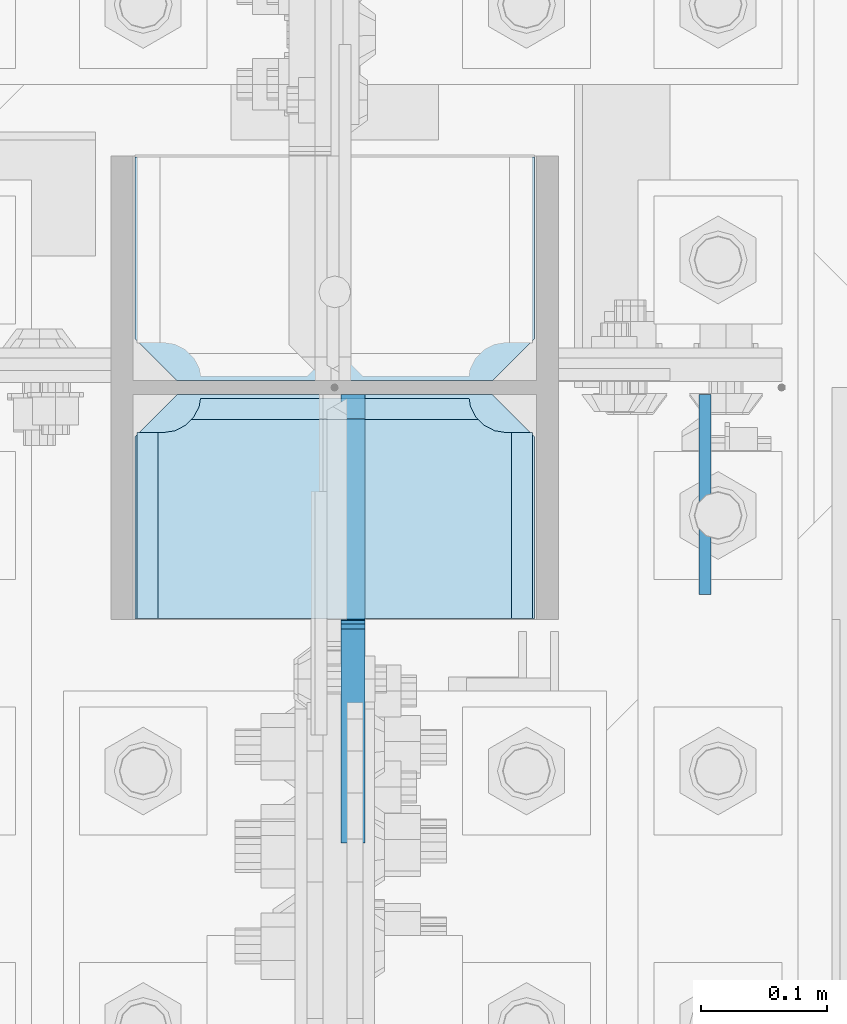
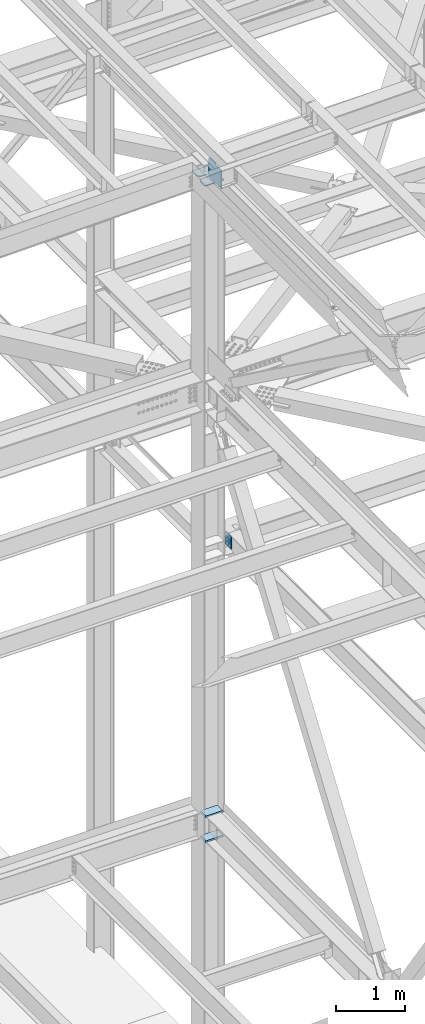
# One storey, part 3200 of 3843: 6 plates, 2 elements without a shape of their own.
"""IFC2X3 building model written with IfcOpenShell, lengths in millimetres."""

from ifc_helpers import new_model, si_unit, frame, origin_with_axes, place, context, subcontext, project, spatial, faceted_brep, material, type_object, element, aggregate, save


model = new_model("IFC2X3")

# Units and contexts
model_context = context("Model", 3, precision=1e-05, world=origin_with_axes())
body_context = subcontext(model_context, "Body", "Model", "MODEL_VIEW")
ifc_project = project(units=[si_unit("LENGTHUNIT", "METRE", prefix="MILLI"), si_unit("AREAUNIT", "SQUARE_METRE"), si_unit("VOLUMEUNIT", "CUBIC_METRE"), si_unit("MASSUNIT", "GRAM", prefix="KILO"), si_unit("TIMEUNIT", "SECOND"), si_unit("PLANEANGLEUNIT", "RADIAN"), si_unit("SOLIDANGLEUNIT", "STERADIAN"), si_unit("THERMODYNAMICTEMPERATUREUNIT", "DEGREE_CELSIUS"), si_unit("LUMINOUSINTENSITYUNIT", "LUMEN")], contexts=[model_context])

# Site, building, storey
site_placement = place(None, origin_with_axes())
site = spatial("IfcSite", under=ifc_project, at=site_placement, CompositionType="ELEMENT")
building_placement = place(site_placement, origin_with_axes())
building = spatial("IfcBuilding", under=site, at=building_placement, Name="Undefined", CompositionType="ELEMENT")
storey_placement = place(building_placement, origin_with_axes())
storey = spatial("IfcBuildingStorey", under=building, at=storey_placement, Name="Undefined", CompositionType="ELEMENT", Elevation=0.0)

# Assembly, plates
assembly_1_placement = place(storey_placement, origin_with_axes())
assembly_1 = element("IfcElementAssembly", 1, at=assembly_1_placement, inside=storey, Name="COLUMN", AssemblyPlace="NOTDEFINED", PredefinedType="RIGID_FRAME")
ifc_material = material(Name="STEEL/A572-50")
plate_type_1 = type_object("IfcPlateType", PredefinedType="NOTDEFINED")
plate_1_placement = place(assembly_1_placement, frame((77171.55, 25799.25625, 45946.8205507398), z_axis=(-1.0, 0.0, 0.0), x_axis=(0.0, -1.0, 0.0)))
plate_1 = element("IfcPlate", 2, at=plate_1_placement, type_object=plate_type_1, material=ifc_material, Name="PLATE", context=body_context, shape_type="Brep", body=[
    faceted_brep([(0.0, -6.3499999046162, 0.0), (0.0, -6.34999999999854, 317.5), (0.0, 6.34999999999854, 317.5), (7.27595761418343e-12, 6.3499999046162, 0.0), (144.462501525879, -6.34999999999854, 317.5), (144.462501525879, 6.34999999999854, 317.5), (177.800003051758, -6.34999999999854, 284.162498474121), (177.800003051758, 6.34999999999854, 284.162498474121), (177.800003051758, -6.34999999999854, 33.3375015258789), (177.800003051758, 6.34999999999854, 33.3375015258789), (144.462501525879, -6.34999999999854, 0.0), (144.462501525879, 6.34999999999854, 0.0)], [[[0, 1, 2, 3]], [[1, 4, 5, 2]], [[4, 6, 7, 5]], [[6, 8, 9, 7]], [[8, 10, 11, 9]], [[10, 0, 3, 11]], [[5, 7, 9, 11, 3, 2]], [[10, 8, 6, 4, 1, 0]]]),
])
plate_type_2 = type_object("IfcPlateType", PredefinedType="NOTDEFINED")
plate_2_placement = place(assembly_1_placement, frame((76854.05, 25432.54375, 45902.4145640179), z_axis=(1.0, 0.0, 0.0), x_axis=(0.0, 1.0, 0.0)))
plate_2 = element("IfcPlate", 3, at=plate_2_placement, type_object=plate_type_2, material=ifc_material, Name="PLATE", context=body_context, shape_type="Brep", body=[
    faceted_brep([(0.0, -9.52500000000146, 0.0), (0.0, -9.52500000000146, 317.5), (0.0, 9.52500000000146, 317.5), (0.0, 9.52500000000146, 0.0), (144.462501525879, -9.52500000000146, 317.5), (144.462501525879, 9.52500000000146, 317.5), (177.800003051758, -9.52500000000146, 284.162498474121), (177.800003051758, 9.52500000000146, 284.162498474121), (177.800003051758, -9.52500000000146, 33.3375015258789), (177.800003051758, 9.52500000000146, 33.3375015258789), (144.462501525879, -9.52500000000146, 0.0), (144.462501525879, 9.52500000000146, 0.0)], [[[0, 1, 2, 3]], [[1, 4, 5, 2]], [[4, 6, 7, 5]], [[6, 8, 9, 7]], [[8, 10, 11, 9]], [[10, 0, 3, 11]], [[5, 7, 9, 11, 3, 2]], [[10, 8, 6, 4, 1, 0]]]),
])
plate_type_3 = type_object("IfcPlateType", PredefinedType="NOTDEFINED")
plate_3_placement = place(assembly_1_placement, frame((76852.4625, 25432.54375, 34358.2625), z_axis=(1.0, 0.0, 0.0), x_axis=(0.0, 1.0, 0.0)))
plate_3 = element("IfcPlate", 4, at=plate_3_placement, type_object=plate_type_3, material=ifc_material, Name="PLATE", context=body_context, shape_type="Brep", body=[
    faceted_brep([(160.070927103505, 10.9213260423567, 48.2144734940957), (158.127465664529, 14.2874999999985, 46.2710120551201), (158.127465664529, 14.2874999999985, 274.403987944883), (160.070927103505, 10.9213260423567, 272.460526505907), (168.479274789282, -3.64235936916521, 268.176259371801), (174.625250047106, -14.2874999999985, 267.202832520343), (174.625250047106, -14.2874999999985, 53.4721674796601), (168.479274789282, -3.64235936916521, 52.4987406282016), (147.637499618531, 14.2874999999985, 19.672284334898), (147.637499618531, -14.2874999999985, 3.17449995232164), (0.0, -14.2874999999985, 3.17449995232164), (0.0, 14.2874999999985, 19.672284334898), (0.0, 14.2874999999985, 301.002715665105), (0.0, -14.2874999999985, 317.500500047681), (147.63749961853, -14.2874999999985, 317.500500047681), (147.63749961853, 14.2874999999985, 301.002715665105), (147.63749961853, -14.2874999999985, 296.862501907352), (147.63749961853, 14.2874999999985, 296.862501907352), (149.113757464445, -14.2874999999985, 287.541776696642), (149.113757464445, 14.2874999999985, 287.541776696642), (153.398024598548, -14.2874999999985, 279.133429010864), (153.398024598548, 14.2874999999985, 279.133429010864), (160.070927103505, -14.2874999999985, 272.460526505907), (168.479274789282, -14.2874999999985, 268.176259371801), (168.479274789282, -14.2874999999985, 52.4987406282016), (160.070927103505, -14.2874999999985, 48.2144734940957), (153.398024598548, -14.2874999999985, 41.5415709891386), (153.398024598548, 14.2874999999985, 41.5415709891386), (149.113757464449, -14.2874999999985, 33.1332233033609), (149.113757464449, 14.2874999999985, 33.1332233033609), (147.63749961853, -14.2874999999985, 23.8124980926514), (147.63749961853, 14.2874999999985, 23.8124980926514)], [[[0, 1, 2, 3, 4, 5, 6, 7]], [[8, 9, 10, 11]], [[12, 13, 14, 15]], [[13, 12, 11, 10]], [[16, 17, 15, 14]], [[16, 18, 19, 17]], [[18, 20, 21, 19]], [[21, 20, 22, 3, 2]], [[22, 23, 4, 3]], [[23, 5, 4]], [[24, 7, 6]], [[24, 25, 0, 7]], [[25, 26, 27, 1, 0]], [[26, 28, 29, 27]], [[28, 30, 31, 29]], [[31, 30, 9, 8]], [[27, 29, 31, 8, 11, 12, 15, 17, 19, 21, 2, 1]], [[9, 30, 28, 26, 25, 24, 6, 5, 23, 22, 20, 18, 16, 14, 13, 10]]]),
])
plate_4_placement = place(assembly_1_placement, frame((76852.4625, 25432.54375, 34796.4125), z_axis=(1.0, 0.0, 0.0), x_axis=(0.0, 1.0, 0.0)))
plate_4 = element("IfcPlate", 5, at=plate_4_placement, type_object=plate_type_3, material=ifc_material, Name="PLATE", context=body_context, shape_type="Brep", body=[
    faceted_brep([(160.070927103505, 10.9213260423567, 48.2144734940957), (158.127465664529, 14.2874999999985, 46.2710120551201), (158.127465664529, 14.2874999999985, 274.403987944883), (160.070927103505, 10.9213260423567, 272.460526505907), (168.479274789282, -3.64235936916521, 268.176259371801), (174.625250047106, -14.2874999999985, 267.202832520343), (174.625250047106, -14.2874999999985, 53.4721674796601), (168.479274789282, -3.64235936916521, 52.4987406282016), (147.637499618531, 14.2874999999985, 19.672284334898), (147.637499618531, -14.2874999999985, 3.17449995232164), (0.0, -14.2874999999985, 3.17449995232164), (0.0, 14.2874999999985, 19.672284334898), (0.0, 14.2874999999985, 301.002715665105), (0.0, -14.2874999999985, 317.500500047681), (147.63749961853, -14.2874999999985, 317.500500047681), (147.63749961853, 14.2874999999985, 301.002715665105), (147.63749961853, -14.2874999999985, 296.862501907352), (147.63749961853, 14.2874999999985, 296.862501907352), (149.113757464445, -14.2874999999985, 287.541776696642), (149.113757464445, 14.2874999999985, 287.541776696642), (153.398024598548, -14.2874999999985, 279.133429010864), (153.398024598548, 14.2874999999985, 279.133429010864), (160.070927103505, -14.2874999999985, 272.460526505907), (168.479274789282, -14.2874999999985, 268.176259371801), (168.479274789282, -14.2874999999985, 52.4987406282016), (160.070927103505, -14.2874999999985, 48.2144734940957), (153.398024598548, -14.2874999999985, 41.5415709891386), (153.398024598548, 14.2874999999985, 41.5415709891386), (149.113757464449, -14.2874999999985, 33.1332233033609), (149.113757464449, 14.2874999999985, 33.1332233033609), (147.63749961853, -14.2874999999985, 23.8124980926514), (147.63749961853, 14.2874999999985, 23.8124980926514)], [[[0, 1, 2, 3, 4, 5, 6, 7]], [[8, 9, 10, 11]], [[12, 13, 14, 15]], [[13, 12, 11, 10]], [[16, 17, 15, 14]], [[16, 18, 19, 17]], [[18, 20, 21, 19]], [[21, 20, 22, 3, 2]], [[22, 23, 4, 3]], [[23, 5, 4]], [[24, 7, 6]], [[24, 25, 0, 7]], [[25, 26, 27, 1, 0]], [[26, 28, 29, 27]], [[28, 30, 31, 29]], [[31, 30, 9, 8]], [[27, 29, 31, 8, 11, 12, 15, 17, 19, 21, 2, 1]], [[9, 30, 28, 26, 25, 24, 6, 5, 23, 22, 20, 18, 16, 14, 13, 10]]]),
])

# Assembly, plate
assembly_2_placement = place(storey_placement, origin_with_axes())
assembly_2 = element("IfcElementAssembly", 6, at=assembly_2_placement, inside=storey, Name="BEAM", AssemblyPlace="NOTDEFINED", PredefinedType="RIGID_FRAME")
plate_type_4 = type_object("IfcPlateType", PredefinedType="NOTDEFINED")
plate_5_placement = place(assembly_2_placement, frame((77307.28125, 25610.34375, 39570.025), z_axis=(0.0, -1.0, 0.0), x_axis=(0.0, 0.0, -1.0)))
plate_5 = element("IfcPlate", 7, at=plate_5_placement, type_object=plate_type_4, material=ifc_material, Name="PLATE", context=body_context, shape_type="Brep", body=[
    faceted_brep([(0.0, -4.76249999999709, 0.0), (0.0, -4.76249999999709, 158.749999526888), (0.0, 4.76249999999709, 158.749999526888), (0.0, 4.76249999999709, 0.0), (228.599999999999, -4.76249999999709, 158.749999526888), (228.599999999999, 4.76249999999709, 158.749999526888), (228.600006103079, -4.7625000004482, 7.27595761418343e-12), (228.600006103079, 4.76249999954598, -7.27595761418343e-12)], [[[0, 1, 2, 3]], [[1, 4, 5, 2]], [[4, 6, 7, 5]], [[6, 0, 3, 7]], [[5, 7, 3, 2]], [[6, 4, 1, 0]]]),
])
aggregate(assembly_2, [plate_5])

# Plate
plate_type_5 = type_object("IfcPlateType", PredefinedType="NOTDEFINED")
plate_6_placement = place(assembly_1_placement, frame((77027.0875006341, 25610.34375, 45930.9895639882), z_axis=(0.0, -0.707106781186682, 0.707106781186413), x_axis=(0.0, -0.707106781186548, -0.707106781186548)))
plate_6 = element("IfcPlate", 8, at=plate_6_placement, type_object=plate_type_5, material=ifc_material, Name="PLATE", context=body_context, shape_type="Brep", body=[
    faceted_brep([(0.0, -9.52500000000146, 0.0), (-215.526146904645, -9.52499999999418, 215.526146904607), (-215.526146904645, 9.52499999999418, 215.526146904607), (0.0, 9.52500000000146, 0.0), (-215.526146904645, -9.52499999999418, 242.466915267682), (-215.526146904645, 9.52499999999418, 242.466915267682), (-102.711679384272, -9.52499999999418, 355.28138278808), (-102.711679384272, 9.52499999999418, 355.28138278808), (-93.731422658424, -9.52499999999418, 346.301126065489), (-93.731422658424, 9.52499999999418, 346.301126065489), (-89.6112461902703, -9.52499999999418, 343.548112165008), (-89.6112461902703, 9.52499999999418, 343.548112165008), (-84.7511666722385, -9.52499999999418, 342.581382242439), (-84.7511666722385, 9.52499999999418, 342.581382242439), (-79.8910871541921, -9.52499999999418, 343.548112165023), (-79.8910871541921, 9.52499999999418, 343.548112165023), (-75.770910686042, -9.52499999999418, 346.301126065511), (-75.770910686042, 9.52499999999418, 346.301126065511), (40.9724185538689, -9.52500000000146, 463.044456243078), (40.9724185538689, 9.52500000000146, 463.044456243078), (265.478821579974, -9.52500000000146, 238.538053217882), (265.478821579974, 9.52500000000146, 238.538053217882), (26.9407683632344, -9.52499999999964, 2.03726813197136e-10), (26.9407683632344, 9.52499999999964, 2.03726813197136e-10)], [[[0, 1, 2, 3]], [[1, 4, 5, 2]], [[4, 6, 7, 5]], [[6, 8, 9, 7]], [[8, 10, 11, 9]], [[10, 12, 13, 11]], [[12, 14, 15, 13]], [[14, 16, 17, 15]], [[16, 18, 19, 17]], [[18, 20, 21, 19]], [[20, 22, 23, 21]], [[22, 0, 3, 23]], [[5, 7, 9, 11, 13, 15, 17, 19, 21, 23, 3, 2]], [[22, 20, 18, 16, 14, 12, 10, 8, 6, 4, 1, 0]]]),
])

aggregate(assembly_1, [plate_3, plate_4, plate_1, plate_2, plate_6])

save(model, "model.ifc")
